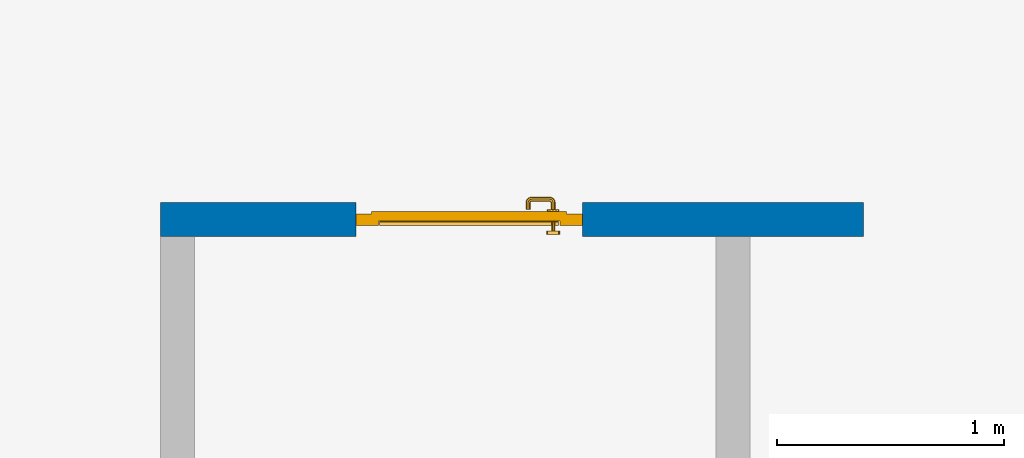
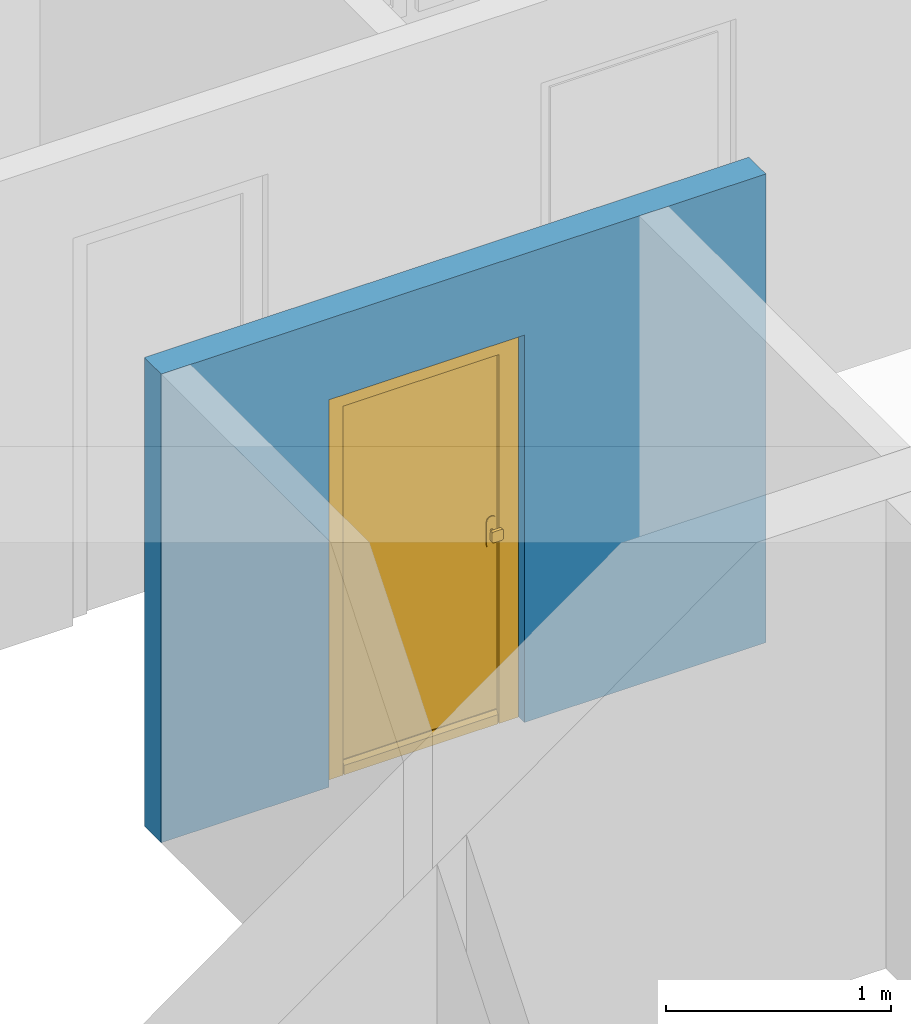
# One storey, part 14 of 54: 1 door, 1 wall, 1 opening.
"""IFC4 building model written with IfcOpenShell, lengths in metres."""

from ifc_helpers import new_model, entity, si_unit, converted_unit, derived_unit, direction, frame, origin_with_axes, place, context, subcontext, project, spatial, polygons, source, transform, mapped, material, type_object, element, fill, save


model = new_model("IFC4")

# Units and contexts
model_context = context("Model", 3, precision=1e-05, world=origin_with_axes(), true_north=direction((0.0, 1.0)))
body_context = subcontext(model_context, "Body", "Model", "MODEL_VIEW")
ifc_project = project(units=[si_unit("LENGTHUNIT", "METRE"), si_unit("AREAUNIT", "SQUARE_METRE"), si_unit("VOLUMEUNIT", "CUBIC_METRE"), converted_unit("PLANEANGLEUNIT", "DEGREE", entity("IfcPlaneAngleMeasure", 0.0174532925199), si_unit("PLANEANGLEUNIT", "RADIAN"), dimensions=[0, 0, 0, 0, 0, 0, 0]), converted_unit("TIMEUNIT", "Year", entity("IfcTimeMeasure", 31556926.0), si_unit("TIMEUNIT", "SECOND"), dimensions=[0, 0, 1, 0, 0, 0, 0]), si_unit("MASSUNIT", "GRAM", prefix="KILO"), si_unit("THERMODYNAMICTEMPERATUREUNIT", "DEGREE_CELSIUS"), si_unit("LUMINOUSINTENSITYUNIT", "LUMEN"), si_unit("ENERGYUNIT", "JOULE", prefix="MEGA"), derived_unit("THERMALCONDUCTANCEUNIT", [(si_unit("POWERUNIT", "WATT"), 1), (si_unit("LENGTHUNIT", "METRE"), -1), (si_unit("THERMODYNAMICTEMPERATUREUNIT", "KELVIN"), -1)]), derived_unit("SPECIFICHEATCAPACITYUNIT", [(si_unit("ENERGYUNIT", "JOULE"), 1), (si_unit("MASSUNIT", "GRAM", prefix="KILO"), -1), (si_unit("THERMODYNAMICTEMPERATUREUNIT", "KELVIN"), -1)]), derived_unit("MASSDENSITYUNIT", [(si_unit("MASSUNIT", "GRAM", prefix="KILO"), 1), (si_unit("VOLUMEUNIT", "CUBIC_METRE"), -1)])], contexts=[model_context])

# Site, building, storey
site_placement = place(None, origin_with_axes())
site = spatial("IfcSite", under=ifc_project, at=site_placement, CompositionType="ELEMENT")
building_placement = place(site_placement, origin_with_axes())
building = spatial("IfcBuilding", under=site, at=building_placement, CompositionType="ELEMENT")
storey_placement = place(building_placement, frame((0.0, 0.0, 6.29), z_axis=(0.0, 0.0, 1.0), x_axis=(1.0, 0.0, 0.0)))
storey = spatial("IfcBuildingStorey", under=building, at=storey_placement, Name="2. Geschoss", CompositionType="ELEMENT", Elevation=6.29)

# Wall, opening, door
ifc_material = material()
wall_type = type_object("IfcWallType", Name="150", PredefinedType="NOTDEFINED")
wall_placement = place(storey_placement, frame((-4.4421993804, 3.97118776896, 0.0), z_axis=(0.0, 0.0, 1.0), x_axis=(-1.0, 0.0, 0.0)))
wall = element("IfcWall", 1, at=wall_placement, inside=storey, type_object=wall_type, material=ifc_material, Name="Wand-002", PredefinedType="NOTDEFINED", context=body_context, shape_type="Tessellation", body=[
    polygons([(2.23891244988, 0.0, 2.1), (2.23891244988, 0.0, 0.0), (3.1, 0.0, 0.0), (3.1, 0.0, 2.54), (0.0, 0.0, 2.54), (0.0, 0.0, 0.0), (1.23891244988, 0.0, 0.0), (1.23891244988, 0.0, 2.1), (2.23891244988, 0.1, 2.1), (2.23891244988, 0.1, 0.0), (2.23891244988, 0.15, 0.0), (3.1, 0.15, 0.0), (3.1, 0.15, 2.54), (0.0, 0.15, 2.54), (0.0, 0.15, 0.0), (1.23891244988, 0.1, 0.0), (1.23891244988, 0.15, 0.0), (1.23891244988, 0.1, 2.1), (2.23891244988, 0.15, 2.1), (1.23891244988, 0.15, 2.1)], [[[1, 2, 3, 4, 5, 6, 7, 8]], [[2, 1, 9, 10]], [[2, 10, 11, 12, 3]], [[4, 3, 12, 13]], [[5, 4, 13, 14]], [[14, 15, 6, 5]], [[16, 7, 6, 15, 17]], [[8, 7, 16, 18]], [[1, 8, 18, 9]], [[10, 9, 19, 11]], [[12, 11, 19, 20, 17, 15, 14, 13]], [[18, 16, 17, 20]], [[9, 18, 20, 19]]], closed=True),
])
opening_placement = place(wall_placement, frame((1.73891244988, 0.0, 0.0), z_axis=(0.0, 0.0, 1.0), x_axis=(1.0, 0.0, 0.0)))
opening = element("IfcOpeningElement", 2, at=opening_placement, cuts=wall, context=body_context, identifier="Reference", shape_type="Tessellation", body=[
    polygons([(-0.5, 0.1, 0.0), (-0.5, 0.1, 2.1), (-0.5, 0.151, 2.1), (-0.5, 0.151, 0.0), (-0.5, -0.001, 0.0), (-0.5, -0.001, 2.1), (0.5, 0.1, 2.1), (0.5, 0.151, 2.1), (0.5, -0.001, 2.1), (0.5, 0.151, 0.0), (0.5, 0.1, 0.0), (0.5, -0.001, 0.0)], [[[1, 2, 3, 4]], [[2, 1, 5, 6]], [[7, 8, 3, 2, 6, 9]], [[8, 10, 4, 3]], [[1, 4, 10, 11, 12, 5]], [[6, 5, 12, 9]], [[7, 11, 10, 8]], [[11, 7, 9, 12]]], closed=True),
])
door_type = type_object("IfcDoorType", Name="Eingang 01 1-Fl 26", OperationType="SINGLE_SWING_LEFT", PredefinedType="DOOR")
shared_shape = source(origin_with_axes(), body_context, "Body", "Tessellation", [
    polygons([(-0.5, -0.05, 0.0), (-0.5, -0.05, 2.1), (-0.5, -0.03, 2.1), (-0.5, -0.03, 0.0), (-0.4, -0.05, 0.0), (-0.4, -0.05, 2.0), (-0.1301, -0.05, 2.0), (-0.0001, -0.05, 2.0), (0.4, -0.05, 2.0), (0.4, -0.05, 0.0), (0.5, -0.05, 0.0), (0.5, -0.05, 2.1), (0.5, -0.03, 2.1), (0.5, -0.03, 0.0), (0.4, -0.03, 0.0), (0.4, -0.03, 2.0), (-0.0001, -0.03, 2.0), (-0.1301, -0.03, 2.0), (-0.4, -0.03, 2.0), (-0.4, -0.03, 0.0)], [[[1, 2, 3, 4]], [[1, 5, 6, 7, 8, 9, 10, 11, 12, 2]], [[2, 12, 13, 3]], [[4, 3, 13, 14, 15, 16, 17, 18, 19, 20]], [[5, 1, 4, 20]], [[6, 5, 20, 19]], [[7, 6, 19, 18]], [[8, 7, 18, 17]], [[9, 8, 17, 16]], [[10, 9, 16, 15]], [[11, 10, 15, 14]], [[12, 11, 14, 13]]], closed=True),
    polygons([(-0.5, -0.03, 0.0), (-0.5, -0.03, 2.1), (-0.5, 0.0, 2.1), (-0.5, 0.0, 0.0), (-0.43, -0.03, 0.0), (-0.43, -0.03, 2.03), (-0.1001, -0.03, 2.03), (-0.0301, -0.03, 2.03), (0.43, -0.03, 2.03), (0.43, -0.03, 0.0), (0.5, -0.03, 0.0), (0.5, -0.03, 2.1), (0.5, 0.0, 2.1), (0.5, 0.0, 0.0), (0.43, 0.0, 0.0), (0.43, 0.0, 2.03), (-0.0301, 0.0, 2.03), (-0.1001, 0.0, 2.03), (-0.43, 0.0, 2.03), (-0.43, 0.0, 0.0)], [[[1, 2, 3, 4]], [[1, 5, 6, 7, 8, 9, 10, 11, 12, 2]], [[2, 12, 13, 3]], [[4, 3, 13, 14, 15, 16, 17, 18, 19, 20]], [[5, 1, 4, 20]], [[6, 5, 20, 19]], [[7, 6, 19, 18]], [[8, 7, 18, 17]], [[9, 8, 17, 16]], [[10, 9, 16, 15]], [[11, 10, 15, 14]], [[12, 11, 14, 13]]], closed=True),
    polygons([(-0.43, 0.01, 0.0), (-0.43, 0.01, 2.03), (0.43, 0.01, 2.03), (0.43, 0.01, 0.0), (-0.43, -0.03, 0.0), (-0.43, -0.03, 2.03), (0.43, -0.03, 2.03), (0.43, -0.03, 0.0)], [[[1, 2, 3, 4]], [[1, 5, 6, 2]], [[2, 6, 7, 3]], [[3, 7, 8, 4]], [[4, 8, 5, 1]], [[8, 7, 6, 5]]], closed=True),
    polygons([(-0.395, -0.05, 0.0), (0.395, -0.05, 0.0), (0.395, -0.05, 0.05), (-0.395, -0.05, 0.05), (-0.395, -0.03, 0.0), (0.395, -0.03, 0.0), (0.395, -0.03, 0.07), (0.395, -0.035, 0.07), (-0.395, -0.035, 0.07), (-0.395, -0.03, 0.07)], [[[1, 2, 3, 4]], [[5, 6, 2, 1]], [[2, 6, 7, 8, 3]], [[4, 3, 8, 9]], [[1, 4, 9, 10, 5]], [[10, 7, 6, 5]], [[9, 8, 7, 10]]], closed=True),
    polygons([(0.3835, 0.02, 1.0733826859), (0.37, 0.02, 1.077), (0.37, 0.0199, 1.077), (0.3835, 0.0199, 1.0733826859), (0.393382685902, 0.02, 1.0635), (0.397, 0.02, 1.05), (0.393382685902, 0.02, 1.0365), (0.3835, 0.02, 1.0266173141), (0.37, 0.02, 1.023), (0.3565, 0.02, 1.0266173141), (0.346617314098, 0.02, 1.0365), (0.343, 0.02, 1.05), (0.346617314098, 0.02, 1.0635), (0.3565, 0.02, 1.0733826859), (0.3565, 0.0199, 1.0733826859), (0.37, 0.0101, 1.077), (0.3835, 0.0101, 1.0733826859), (0.393382685902, 0.0199, 1.0635), (0.397, 0.0199, 1.05), (0.393382685902, 0.0199, 1.0365), (0.3835, 0.0199, 1.0266173141), (0.37, 0.0199, 1.023), (0.3565, 0.0199, 1.0266173141), (0.346617314098, 0.0199, 1.0365), (0.343, 0.0199, 1.05), (0.346617314098, 0.0199, 1.0635), (0.3565, 0.0101, 1.0733826859), (0.37, 0.01, 1.077), (0.3835, 0.01, 1.0733826859), (0.393382685902, 0.0101, 1.0635), (0.397, 0.0101, 1.05), (0.393382685902, 0.0101, 1.0365), (0.3835, 0.0101, 1.0266173141), (0.37, 0.0101, 1.023), (0.3565, 0.0101, 1.0266173141), (0.346617314098, 0.0101, 1.0365), (0.343, 0.0101, 1.05), (0.346617314098, 0.0101, 1.0635), (0.3565, 0.01, 1.0733826859), (0.346617314098, 0.01, 1.0635), (0.343, 0.01, 1.05), (0.346617314098, 0.01, 1.0365), (0.3565, 0.01, 1.0266173141), (0.37, 0.01, 1.023), (0.3835, 0.01, 1.0266173141), (0.393382685902, 0.01, 1.0365), (0.397, 0.01, 1.05), (0.393382685902, 0.01, 1.0635)], [[[1, 2, 3, 4]], [[2, 1, 5, 6, 7, 8, 9, 10, 11, 12, 13, 14]], [[2, 14, 15, 3]], [[4, 3, 16, 17]], [[5, 1, 4, 18]], [[6, 5, 18, 19]], [[7, 6, 19, 20]], [[8, 7, 20, 21]], [[9, 8, 21, 22]], [[10, 9, 22, 23]], [[11, 10, 23, 24]], [[12, 11, 24, 25]], [[13, 12, 25, 26]], [[14, 13, 26, 15]], [[3, 15, 27, 16]], [[17, 16, 28, 29]], [[18, 4, 17, 30]], [[19, 18, 30, 31]], [[20, 19, 31, 32]], [[21, 20, 32, 33]], [[22, 21, 33, 34]], [[23, 22, 34, 35]], [[24, 23, 35, 36]], [[25, 24, 36, 37]], [[26, 25, 37, 38]], [[15, 26, 38, 27]], [[16, 27, 39, 28]], [[28, 39, 40, 41, 42, 43, 44, 45, 46, 47, 48, 29]], [[30, 17, 29, 48]], [[31, 30, 48, 47]], [[32, 31, 47, 46]], [[33, 32, 46, 45]], [[34, 33, 45, 44]], [[35, 34, 44, 43]], [[36, 35, 43, 42]], [[37, 36, 42, 41]], [[38, 37, 41, 40]], [[27, 38, 40, 39]]], closed=True),
    polygons([(0.362532169224, 0.019, 0.959692280177), (0.363279754556, 0.019, 0.961639806549), (0.35705, 0.019, 0.972430057958), (0.347569942042, 0.019, 0.96295), (0.365, 0.019, 0.952886751346), (0.365, 0.019, 0.9544), (0.362532169224, 0.02, 0.959692280177), (0.363279754556, 0.02, 0.961639806549), (0.364624817685, 0.02, 0.965143815798), (0.364624817685, 0.019, 0.965143815798), (0.37, 0.019, 0.967425445323), (0.37, 0.019, 0.9759), (0.357, 0.019, 0.972516660498), (0.347483339502, 0.019, 0.963), (0.365, 0.019, 0.95), (0.3441, 0.019, 0.95), (0.365, 0.019, 0.947113248654), (0.365, 0.019, 0.941339745962), (0.365, 0.019, 0.9375), (0.365, 0.02, 0.9375), (0.365, 0.02, 0.941339745962), (0.365, 0.02, 0.947113248654), (0.365, 0.02, 0.95), (0.365, 0.02, 0.952886751346), (0.365, 0.02, 0.9544), (0.346703916638, 0.02, 0.96345), (0.35655, 0.02, 0.973296083362), (0.37, 0.02, 0.9769), (0.37, 0.02, 0.967425445323), (0.375375182315, 0.019, 0.965143815798), (0.376720245444, 0.019, 0.961639806549), (0.38295, 0.019, 0.972430057958), (0.37, 0.019, 0.976), (0.357, 0.0189, 0.972516660498), (0.347483339502, 0.0189, 0.963), (0.344, 0.019, 0.95), (0.347569942042, 0.019, 0.93705), (0.35705, 0.019, 0.927569942042), (0.37, 0.019, 0.9241), (0.37, 0.019, 0.9325), (0.366464466094, 0.019, 0.933964466094), (0.366464466094, 0.02, 0.933964466094), (0.37, 0.02, 0.9231), (0.35655, 0.02, 0.926703916638), (0.37, 0.02, 0.9325), (0.346703916638, 0.02, 0.93655), (0.3431, 0.02, 0.95), (0.346617314098, 0.02, 0.9635), (0.3565, 0.02, 0.973382685902), (0.37, 0.02, 0.977), (0.375375182315, 0.02, 0.965143815798), (0.38345, 0.02, 0.973296083362), (0.376720245444, 0.02, 0.961639806549), (0.377467830776, 0.02, 0.959692280177), (0.377467830776, 0.019, 0.959692280177), (0.375, 0.019, 0.9544), (0.375, 0.019, 0.952886751346), (0.392430057958, 0.019, 0.96295), (0.383, 0.019, 0.972516660498), (0.37, 0.0189, 0.976), (0.357, 0.0101, 0.972516660498), (0.347483339502, 0.0101, 0.963), (0.344, 0.0189, 0.95), (0.347483339502, 0.019, 0.937), (0.357, 0.019, 0.927483339502), (0.37, 0.019, 0.924), (0.38295, 0.019, 0.927569942042), (0.375, 0.019, 0.941339745962), (0.375, 0.019, 0.9375), (0.373535533906, 0.019, 0.933964466094), (0.37, 0.02, 0.923), (0.3565, 0.02, 0.926617314098), (0.38345, 0.02, 0.926703916638), (0.373535533906, 0.02, 0.933964466094), (0.375, 0.02, 0.9375), (0.375, 0.02, 0.941339745962), (0.346617314098, 0.02, 0.9365), (0.343, 0.02, 0.95), (0.346617314098, 0.0199, 0.9635), (0.3565, 0.0199, 0.973382685902), (0.37, 0.0199, 0.977), (0.3835, 0.02, 0.973382685902), (0.393296083362, 0.02, 0.96345), (0.375, 0.02, 0.952886751346), (0.375, 0.02, 0.9544), (0.375, 0.02, 0.95), (0.375, 0.02, 0.947113248654), (0.375, 0.019, 0.947113248654), (0.375, 0.019, 0.95), (0.3959, 0.019, 0.95), (0.392516660498, 0.019, 0.963), (0.383, 0.0189, 0.972516660498), (0.37, 0.0101, 0.976), (0.357, 0.01, 0.972516660498), (0.347483339502, 0.01, 0.963), (0.344, 0.0101, 0.95), (0.347483339502, 0.0189, 0.937), (0.357, 0.0189, 0.927483339502), (0.37, 0.0189, 0.924), (0.383, 0.019, 0.927483339502), (0.392430057958, 0.019, 0.93705), (0.37, 0.0199, 0.923), (0.3565, 0.0199, 0.926617314098), (0.3835, 0.02, 0.926617314098), (0.393296083362, 0.02, 0.93655), (0.346617314098, 0.0199, 0.9365), (0.343, 0.0199, 0.95), (0.346617314098, 0.0101, 0.9635), (0.3565, 0.0101, 0.973382685902), (0.37, 0.0101, 0.977), (0.3835, 0.0199, 0.973382685902), (0.393382685902, 0.02, 0.9635), (0.3969, 0.02, 0.95), (0.396, 0.019, 0.95), (0.392516660498, 0.0189, 0.963), (0.383, 0.0101, 0.972516660498), (0.37, 0.01, 0.976), (0.35695, 0.01, 0.972603263039), (0.347396736961, 0.01, 0.96305), (0.344, 0.01, 0.95), (0.347483339502, 0.0101, 0.937), (0.357, 0.0101, 0.927483339502), (0.37, 0.0101, 0.924), (0.383, 0.0189, 0.927483339502), (0.392516660498, 0.019, 0.937), (0.37, 0.0101, 0.923), (0.3565, 0.0101, 0.926617314098), (0.3835, 0.0199, 0.926617314098), (0.393382685902, 0.02, 0.9365), (0.346617314098, 0.0101, 0.9365), (0.343, 0.0101, 0.95), (0.346617314098, 0.01, 0.9635), (0.3565, 0.01, 0.973382685902), (0.37, 0.01, 0.977), (0.3835, 0.0101, 0.973382685902), (0.393382685902, 0.0199, 0.9635), (0.397, 0.02, 0.95), (0.396, 0.0189, 0.95), (0.392516660498, 0.0101, 0.963), (0.383, 0.01, 0.972516660498), (0.37, 0.01, 0.9761), (0.35655, 0.01, 0.973296083362), (0.346703916638, 0.01, 0.96345), (0.3439, 0.01, 0.95), (0.347483339502, 0.01, 0.937), (0.357, 0.01, 0.927483339502), (0.37, 0.01, 0.924), (0.383, 0.0101, 0.927483339502), (0.392516660498, 0.0189, 0.937), (0.37, 0.01, 0.923), (0.3565, 0.01, 0.926617314098), (0.3835, 0.0101, 0.926617314098), (0.393382685902, 0.0199, 0.9365), (0.346617314098, 0.01, 0.9365), (0.343, 0.01, 0.95), (0.37, 0.01, 0.9769), (0.3835, 0.01, 0.973382685902), (0.393382685902, 0.0101, 0.9635), (0.397, 0.0199, 0.95), (0.396, 0.0101, 0.95), (0.392516660498, 0.01, 0.963), (0.38305, 0.01, 0.972603263039), (0.3431, 0.01, 0.95), (0.347396736961, 0.01, 0.93695), (0.35695, 0.01, 0.927396736961), (0.37, 0.01, 0.9239), (0.383, 0.01, 0.927483339502), (0.392516660498, 0.0101, 0.937), (0.37, 0.01, 0.9231), (0.35655, 0.01, 0.926703916638), (0.3835, 0.01, 0.926617314098), (0.393382685902, 0.0101, 0.9365), (0.346703916638, 0.01, 0.93655), (0.38345, 0.01, 0.973296083362), (0.393382685902, 0.01, 0.9635), (0.397, 0.0101, 0.95), (0.396, 0.01, 0.95), (0.392603263039, 0.01, 0.96305), (0.38305, 0.01, 0.927396736961), (0.392516660498, 0.01, 0.937), (0.38345, 0.01, 0.926703916638), (0.393382685902, 0.01, 0.9365), (0.393296083362, 0.01, 0.96345), (0.397, 0.01, 0.95), (0.3961, 0.01, 0.95), (0.392603263039, 0.01, 0.93695), (0.393296083362, 0.01, 0.93655), (0.3969, 0.01, 0.95)], [[[1, 2, 3, 4, 5, 6]], [[1, 7, 8, 9, 10, 2]], [[10, 11, 12, 3, 2]], [[4, 3, 13, 14]], [[15, 5, 4, 16]], [[6, 5, 15, 17, 18, 19, 20, 21, 22, 23, 24, 25]], [[6, 25, 7, 1]], [[7, 25, 24, 26, 27, 8]], [[9, 8, 27, 28, 29]], [[10, 9, 29, 11]], [[30, 31, 32, 12, 11]], [[3, 12, 33, 13]], [[14, 13, 34, 35]], [[16, 4, 14, 36]], [[17, 15, 16, 37]], [[18, 17, 37, 38]], [[38, 39, 40, 41, 19, 18]], [[19, 41, 42, 20]], [[43, 44, 21, 20, 42, 45]], [[22, 21, 44, 46]], [[23, 22, 46, 47]], [[24, 23, 47, 26]], [[48, 49, 27, 26]], [[49, 50, 28, 27]], [[51, 29, 28, 52, 53]], [[11, 29, 51, 30]], [[30, 51, 53, 54, 55, 31]], [[55, 56, 57, 58, 32, 31]], [[12, 32, 59, 33]], [[13, 33, 60, 34]], [[35, 34, 61, 62]], [[36, 14, 35, 63]], [[37, 16, 36, 64]], [[38, 37, 64, 65]], [[39, 38, 65, 66]], [[39, 67, 68, 69, 70, 40]], [[41, 40, 45, 42]], [[71, 72, 44, 43]], [[73, 43, 45, 74, 75, 76]], [[72, 77, 46, 44]], [[77, 78, 47, 46]], [[78, 48, 26, 47]], [[79, 80, 49, 48]], [[80, 81, 50, 49]], [[50, 82, 52, 28]], [[54, 53, 52, 83, 84, 85]], [[55, 54, 85, 56]], [[85, 84, 86, 87, 76, 75, 69, 68, 88, 89, 57, 56]], [[57, 89, 90, 58]], [[32, 58, 91, 59]], [[33, 59, 92, 60]], [[34, 60, 93, 61]], [[62, 61, 94, 95]], [[63, 35, 62, 96]], [[64, 36, 63, 97]], [[65, 64, 97, 98]], [[66, 65, 98, 99]], [[67, 39, 66, 100]], [[88, 68, 67, 101]], [[70, 69, 75, 74]], [[40, 70, 74, 45]], [[102, 103, 72, 71]], [[104, 71, 43, 73]], [[76, 87, 105, 73]], [[103, 106, 77, 72]], [[106, 107, 78, 77]], [[107, 79, 48, 78]], [[108, 109, 80, 79]], [[109, 110, 81, 80]], [[81, 111, 82, 50]], [[82, 112, 83, 52]], [[86, 84, 83, 113]], [[87, 86, 113, 105]], [[89, 88, 101, 90]], [[58, 90, 114, 91]], [[59, 91, 115, 92]], [[60, 92, 116, 93]], [[61, 93, 117, 94]], [[95, 94, 118, 119]], [[96, 62, 95, 120]], [[97, 63, 96, 121]], [[98, 97, 121, 122]], [[99, 98, 122, 123]], [[100, 66, 99, 124]], [[101, 67, 100, 125]], [[126, 127, 103, 102]], [[128, 102, 71, 104]], [[129, 104, 73, 105]], [[127, 130, 106, 103]], [[130, 131, 107, 106]], [[131, 108, 79, 107]], [[132, 133, 109, 108]], [[133, 134, 110, 109]], [[110, 135, 111, 81]], [[111, 136, 112, 82]], [[112, 137, 113, 83]], [[137, 129, 105, 113]], [[90, 101, 125, 114]], [[91, 114, 138, 115]], [[92, 115, 139, 116]], [[93, 116, 140, 117]], [[94, 117, 141, 118]], [[119, 118, 142, 143]], [[120, 95, 119, 144]], [[121, 96, 120, 145]], [[122, 121, 145, 146]], [[123, 122, 146, 147]], [[124, 99, 123, 148]], [[125, 100, 124, 149]], [[150, 151, 127, 126]], [[152, 126, 102, 128]], [[153, 128, 104, 129]], [[151, 154, 130, 127]], [[154, 155, 131, 130]], [[155, 132, 108, 131]], [[143, 142, 133, 132]], [[142, 156, 134, 133]], [[134, 157, 135, 110]], [[135, 158, 136, 111]], [[136, 159, 137, 112]], [[159, 153, 129, 137]], [[114, 125, 149, 138]], [[115, 138, 160, 139]], [[116, 139, 161, 140]], [[117, 140, 162, 141]], [[118, 141, 156, 142]], [[144, 119, 143, 163]], [[145, 120, 144, 164]], [[146, 145, 164, 165]], [[147, 146, 165, 166]], [[148, 123, 147, 167]], [[149, 124, 148, 168]], [[169, 170, 151, 150]], [[171, 150, 126, 152]], [[172, 152, 128, 153]], [[170, 173, 154, 151]], [[173, 163, 155, 154]], [[163, 143, 132, 155]], [[156, 174, 157, 134]], [[157, 175, 158, 135]], [[158, 176, 159, 136]], [[176, 172, 153, 159]], [[138, 149, 168, 160]], [[139, 160, 177, 161]], [[140, 161, 178, 162]], [[141, 162, 174, 156]], [[164, 144, 163, 173]], [[165, 164, 173, 170]], [[166, 165, 170, 169]], [[167, 147, 166, 179]], [[168, 148, 167, 180]], [[181, 169, 150, 171]], [[182, 171, 152, 172]], [[174, 183, 175, 157]], [[175, 184, 176, 158]], [[184, 182, 172, 176]], [[160, 168, 180, 177]], [[161, 177, 185, 178]], [[162, 178, 183, 174]], [[179, 166, 169, 181]], [[180, 167, 179, 186]], [[187, 181, 171, 182]], [[183, 188, 184, 175]], [[188, 187, 182, 184]], [[177, 180, 186, 185]], [[178, 185, 188, 183]], [[186, 179, 181, 187]], [[185, 186, 187, 188]]], closed=True),
    polygons([(0.38, 0.02, 1.05), (0.377071067812, 0.02, 1.04292893219), (0.377071067812, 0.050696439392, 1.04292893219), (0.38, 0.0509849140336, 1.05), (0.37, 0.02, 1.04), (0.37, 0.05, 1.04), (0.375518993221, 0.0584992452783, 1.04292893219), (0.378277987014, 0.0596420579258, 1.05), (0.377071067812, 0.02, 1.05707106781), (0.377071067812, 0.050696439392, 1.05707106781), (0.362928932188, 0.02, 1.04292893219), (0.362928932188, 0.049303560608, 1.04292893219), (0.368858192988, 0.0557402514855, 1.04), (0.370704557509, 0.0657045575088, 1.04292893219), (0.372816199938, 0.0678161999379, 1.05), (0.375518993221, 0.0584992452783, 1.05707106781), (0.37, 0.02, 1.06), (0.37, 0.05, 1.06), (0.36, 0.02, 1.05), (0.36, 0.0490150859664, 1.05), (0.362197392755, 0.0529812576926, 1.04292893219), (0.365606601718, 0.0606066017178, 1.04), (0.363499245278, 0.0705189932208, 1.04292893219), (0.364642057926, 0.0732779870137, 1.05), (0.370704557509, 0.0657045575088, 1.05707106781), (0.368858192988, 0.0557402514855, 1.06), (0.362928932188, 0.02, 1.05707106781), (0.362928932188, 0.049303560608, 1.05707106781), (0.359438398962, 0.0518384450452, 1.05), (0.360508645927, 0.0555086459268, 1.04292893219), (0.360740251485, 0.0638581929877, 1.04), (0.355696439392, 0.0720710678119, 1.04292893219), (0.355984914034, 0.075, 1.05), (0.363499245278, 0.0705189932208, 1.05707106781), (0.365606601718, 0.0606066017178, 1.06), (0.362197392755, 0.0529812576926, 1.05707106781), (0.358397003498, 0.0533970034977, 1.05), (0.357981257693, 0.0571973927545, 1.04292893219), (0.355, 0.065, 1.04), (0.274303560608, 0.0720710678119, 1.04292893219), (0.274015085966, 0.075, 1.05), (0.355696439392, 0.0720710678119, 1.05707106781), (0.360740251485, 0.0638581929877, 1.06), (0.360508645927, 0.0555086459268, 1.05707106781), (0.356838445045, 0.0544383989617, 1.05), (0.354303560608, 0.0579289321881, 1.04292893219), (0.275, 0.065, 1.04), (0.266500754722, 0.0705189932208, 1.04292893219), (0.265357942074, 0.0732779870137, 1.05), (0.274303560608, 0.0720710678119, 1.05707106781), (0.355, 0.065, 1.06), (0.357981257693, 0.0571973927545, 1.05707106781), (0.354015085966, 0.055, 1.05), (0.275696439392, 0.0579289321881, 1.04292893219), (0.269259748515, 0.0638581929877, 1.04), (0.259295442491, 0.0657045575088, 1.04292893219), (0.257183800062, 0.0678161999379, 1.05), (0.266500754722, 0.0705189932208, 1.05707106781), (0.275, 0.065, 1.06), (0.354303560608, 0.0579289321881, 1.05707106781), (0.275984914034, 0.055, 1.05), (0.272018742307, 0.0571973927545, 1.04292893219), (0.264393398282, 0.0606066017178, 1.04), (0.254481006779, 0.0584992452783, 1.04292893219), (0.251722012986, 0.0596420579258, 1.05), (0.259295442491, 0.0657045575088, 1.05707106781), (0.269259748515, 0.0638581929877, 1.06), (0.275696439392, 0.0579289321881, 1.05707106781), (0.273161554955, 0.0544383989617, 1.05), (0.269491354073, 0.0555086459268, 1.04292893219), (0.261141807012, 0.0557402514855, 1.04), (0.252928932188, 0.050696439392, 1.04292893219), (0.25, 0.0509849140336, 1.05), (0.254481006779, 0.0584992452783, 1.05707106781), (0.264393398282, 0.0606066017178, 1.06), (0.272018742307, 0.0571973927545, 1.05707106781), (0.271602996502, 0.0533970034977, 1.05), (0.267802607245, 0.0529812576926, 1.04292893219), (0.26, 0.05, 1.04), (0.252928932188, 0.02, 1.04292893219), (0.25, 0.02, 1.05), (0.252928932188, 0.050696439392, 1.05707106781), (0.261141807012, 0.0557402514855, 1.06), (0.269491354073, 0.0555086459268, 1.05707106781), (0.270561601038, 0.0518384450452, 1.05), (0.267071067812, 0.049303560608, 1.04292893219), (0.26, 0.02, 1.04), (0.267071067812, 0.02, 1.04292893219), (0.27, 0.02, 1.05), (0.267071067812, 0.02, 1.05707106781), (0.26, 0.02, 1.06), (0.252928932188, 0.02, 1.05707106781), (0.26, 0.05, 1.06), (0.267802607245, 0.0529812576926, 1.05707106781), (0.27, 0.0490150859664, 1.05), (0.267071067812, 0.049303560608, 1.05707106781)], [[[1, 2, 3, 4]], [[2, 5, 6, 3]], [[4, 3, 7, 8]], [[9, 1, 4, 10]], [[5, 11, 12, 6]], [[3, 6, 13, 7]], [[8, 7, 14, 15]], [[10, 4, 8, 16]], [[17, 9, 10, 18]], [[11, 19, 20, 12]], [[6, 12, 21, 13]], [[7, 13, 22, 14]], [[15, 14, 23, 24]], [[16, 8, 15, 25]], [[18, 10, 16, 26]], [[27, 17, 18, 28]], [[19, 27, 28, 20]], [[12, 20, 29, 21]], [[13, 21, 30, 22]], [[14, 22, 31, 23]], [[24, 23, 32, 33]], [[25, 15, 24, 34]], [[26, 16, 25, 35]], [[28, 18, 26, 36]], [[20, 28, 36, 29]], [[21, 29, 37, 30]], [[22, 30, 38, 31]], [[23, 31, 39, 32]], [[33, 32, 40, 41]], [[34, 24, 33, 42]], [[35, 25, 34, 43]], [[36, 26, 35, 44]], [[29, 36, 44, 37]], [[30, 37, 45, 38]], [[31, 38, 46, 39]], [[32, 39, 47, 40]], [[41, 40, 48, 49]], [[42, 33, 41, 50]], [[43, 34, 42, 51]], [[44, 35, 43, 52]], [[37, 44, 52, 45]], [[38, 45, 53, 46]], [[39, 46, 54, 47]], [[40, 47, 55, 48]], [[49, 48, 56, 57]], [[50, 41, 49, 58]], [[51, 42, 50, 59]], [[52, 43, 51, 60]], [[45, 52, 60, 53]], [[46, 53, 61, 54]], [[47, 54, 62, 55]], [[48, 55, 63, 56]], [[57, 56, 64, 65]], [[58, 49, 57, 66]], [[59, 50, 58, 67]], [[60, 51, 59, 68]], [[53, 60, 68, 61]], [[54, 61, 69, 62]], [[55, 62, 70, 63]], [[56, 63, 71, 64]], [[65, 64, 72, 73]], [[66, 57, 65, 74]], [[67, 58, 66, 75]], [[68, 59, 67, 76]], [[61, 68, 76, 69]], [[62, 69, 77, 70]], [[63, 70, 78, 71]], [[64, 71, 79, 72]], [[73, 72, 80, 81]], [[74, 65, 73, 82]], [[75, 66, 74, 83]], [[76, 67, 75, 84]], [[69, 76, 84, 77]], [[70, 77, 85, 78]], [[71, 78, 86, 79]], [[72, 79, 87, 80]], [[81, 80, 87, 88, 89, 90, 91, 92]], [[82, 73, 81, 92]], [[83, 74, 82, 93]], [[84, 75, 83, 94]], [[77, 84, 94, 85]], [[78, 85, 95, 86]], [[79, 86, 88, 87]], [[86, 95, 89, 88]], [[95, 96, 90, 89]], [[96, 93, 91, 90]], [[93, 82, 92, 91]], [[94, 83, 93, 96]], [[85, 94, 96, 95]]], closed=False),
    polygons([(0.364696699141, -0.035, 1.04469669914), (0.3625, -0.035, 1.05), (0.364696699141, -0.035, 1.05530330086), (0.37, -0.035, 1.0575), (0.375303300859, -0.035, 1.05530330086), (0.3775, -0.035, 1.05), (0.375303300859, -0.035, 1.04469669914), (0.37, -0.035, 1.0425), (0.364696699141, -0.075, 1.04469669914), (0.3625, -0.075, 1.05), (0.364696699141, -0.075, 1.05530330086), (0.37, -0.075, 1.0575), (0.375303300859, -0.075, 1.05530330086), (0.3775, -0.075, 1.05), (0.375303300859, -0.075, 1.04469669914), (0.37, -0.075, 1.0425)], [[[1, 2, 3, 4, 5, 6, 7, 8]], [[1, 9, 10, 2]], [[2, 10, 11, 3]], [[3, 11, 12, 4]], [[4, 12, 13, 5]], [[5, 13, 14, 6]], [[6, 14, 15, 7]], [[7, 15, 16, 8]], [[8, 16, 9, 1]], [[9, 16, 15, 14, 13, 12, 11, 10]]], closed=True),
    polygons([(0.395, -0.03, 0.975), (0.395, -0.035, 0.975), (0.393096988313, -0.035, 0.965432914191), (0.393096988313, -0.03, 0.965432914191), (0.395, -0.03, 1.1), (0.395, -0.035, 1.1), (0.393096988313, -0.035, 1.10956708581), (0.38767766953, -0.035, 1.11767766953), (0.379567085809, -0.035, 1.12309698831), (0.37, -0.035, 1.125), (0.360432914191, -0.035, 1.12309698831), (0.35232233047, -0.035, 1.11767766953), (0.346903011687, -0.035, 1.10956708581), (0.345, -0.035, 1.1), (0.345, -0.035, 0.975), (0.346903011687, -0.035, 0.965432914191), (0.35232233047, -0.035, 0.95732233047), (0.360432914191, -0.035, 0.951903011687), (0.37, -0.035, 0.95), (0.379567085809, -0.035, 0.951903011687), (0.38767766953, -0.035, 0.95732233047), (0.38767766953, -0.03, 0.95732233047), (0.379567085809, -0.03, 0.951903011687), (0.37, -0.03, 0.95), (0.360432914191, -0.03, 0.951903011687), (0.35232233047, -0.03, 0.95732233047), (0.346903011687, -0.03, 0.965432914191), (0.345, -0.03, 0.975), (0.345, -0.03, 1.1), (0.346903011687, -0.03, 1.10956708581), (0.35232233047, -0.03, 1.11767766953), (0.360432914191, -0.03, 1.12309698831), (0.37, -0.03, 1.125), (0.379567085809, -0.03, 1.12309698831), (0.38767766953, -0.03, 1.11767766953), (0.393096988313, -0.03, 1.10956708581)], [[[1, 2, 3, 4]], [[5, 6, 2, 1]], [[2, 6, 7, 8, 9, 10, 11, 12, 13, 14, 15, 16, 17, 18, 19, 20, 21, 3]], [[4, 3, 21, 22]], [[1, 4, 22, 23, 24, 25, 26, 27, 28, 29, 30, 31, 32, 33, 34, 35, 36, 5]], [[36, 7, 6, 5]], [[35, 8, 7, 36]], [[34, 9, 8, 35]], [[33, 10, 9, 34]], [[32, 11, 10, 33]], [[31, 12, 11, 32]], [[30, 13, 12, 31]], [[29, 14, 13, 30]], [[28, 15, 14, 29]], [[27, 16, 15, 28]], [[26, 17, 16, 27]], [[25, 18, 17, 26]], [[24, 19, 18, 25]], [[23, 20, 19, 24]], [[22, 21, 20, 23]]], closed=True),
    polygons([(0.39, -0.075, 1.08), (0.39, -0.09, 1.08), (0.395, -0.09, 1.07866025404), (0.395, -0.075, 1.07866025404), (0.35, -0.075, 1.08), (0.35, -0.09, 1.08), (0.345, -0.09, 1.07866025404), (0.341339745962, -0.09, 1.075), (0.34, -0.09, 1.07), (0.34, -0.09, 1.03), (0.341339745962, -0.09, 1.025), (0.345, -0.09, 1.02133974596), (0.35, -0.09, 1.02), (0.39, -0.09, 1.02), (0.395, -0.09, 1.02133974596), (0.398660254038, -0.09, 1.025), (0.4, -0.09, 1.03), (0.4, -0.09, 1.07), (0.398660254038, -0.09, 1.075), (0.398660254038, -0.075, 1.075), (0.4, -0.075, 1.07), (0.4, -0.075, 1.03), (0.398660254038, -0.075, 1.025), (0.395, -0.075, 1.02133974596), (0.39, -0.075, 1.02), (0.35, -0.075, 1.02), (0.345, -0.075, 1.02133974596), (0.341339745962, -0.075, 1.025), (0.34, -0.075, 1.03), (0.34, -0.075, 1.07), (0.341339745962, -0.075, 1.075), (0.345, -0.075, 1.07866025404)], [[[1, 2, 3, 4]], [[5, 6, 2, 1]], [[2, 6, 7, 8, 9, 10, 11, 12, 13, 14, 15, 16, 17, 18, 19, 3]], [[4, 3, 19, 20]], [[1, 4, 20, 21, 22, 23, 24, 25, 26, 27, 28, 29, 30, 31, 32, 5]], [[32, 7, 6, 5]], [[31, 8, 7, 32]], [[30, 9, 8, 31]], [[29, 10, 9, 30]], [[28, 11, 10, 29]], [[27, 12, 11, 28]], [[26, 13, 12, 27]], [[25, 14, 13, 26]], [[24, 15, 14, 25]], [[23, 16, 15, 24]], [[22, 17, 16, 23]], [[21, 18, 17, 22]], [[20, 19, 18, 21]]], closed=True),
])
door_placement = place(opening_placement, frame((0.4, 0.0, 0.0), z_axis=(0.0, 0.0, 1.0), x_axis=(-1.0, 0.0, 0.0)))
door = element("IfcDoor", 3, at=door_placement, inside=storey, type_object=door_type, OverallHeight=2.1, OverallWidth=1.0, PredefinedType="DOOR", context=body_context, shape_type="MappedRepresentation", body=[
    mapped(shared_shape, transform((0.4, -0.05, 0.0))),
])
fill(opening, door)

save(model, "model.ifc")
